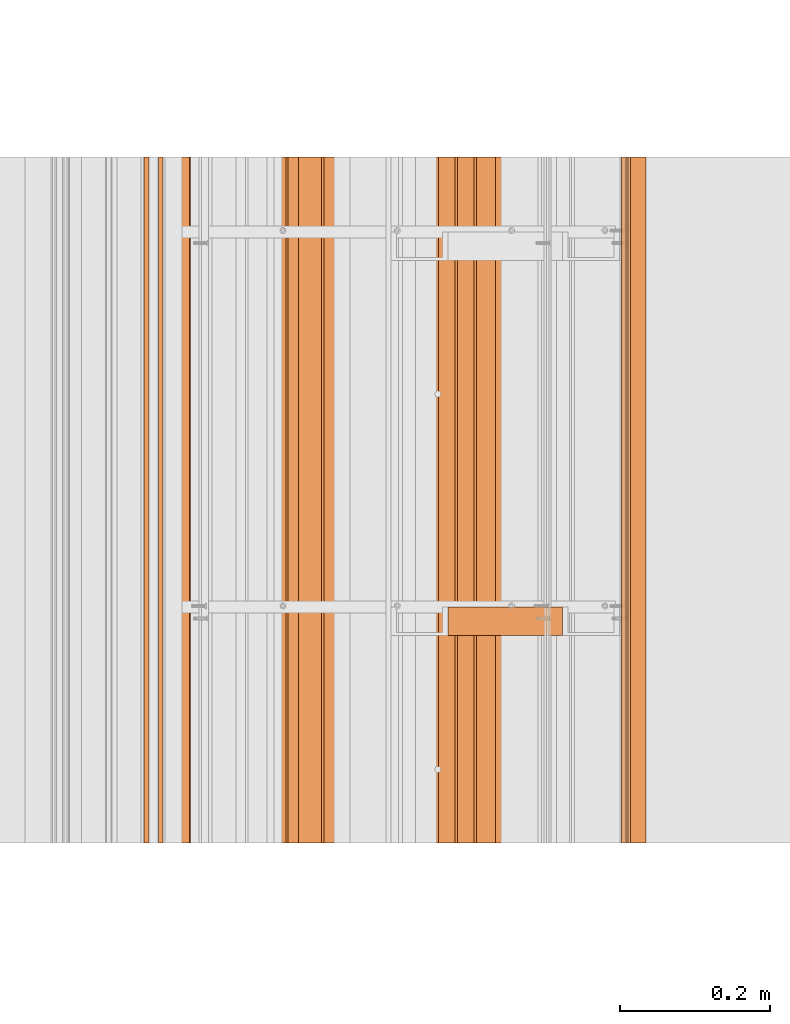
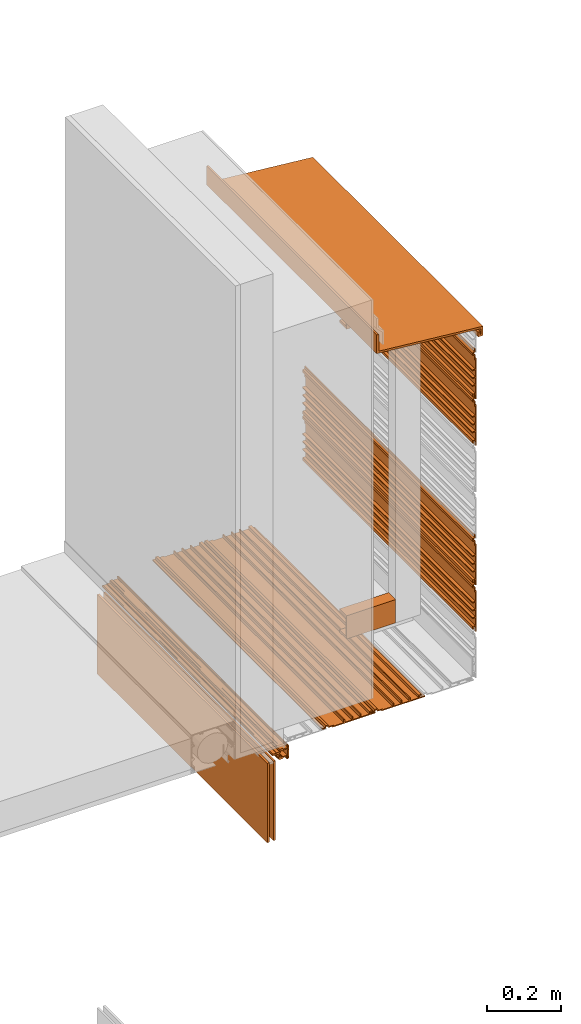
# One storey, part 7 of 36: 12 proxies.
"""IFC2X3 building model written with IfcOpenShell, lengths in feet."""

from ifc_helpers import new_model, entity, si_unit, converted_unit, derived_unit, direction, frame, frame_2d, origin, origin_2d_with_axis, place, context, subcontext, project, spatial, polyline, circle_curve, parameter, trimmed, segment, composite_curve, rectangle, outline, extrude, source, transform, mapped, material, type_object, type_shapes, element, save


model = new_model("IFC2X3")

# Units and contexts
model_context = context("Model", 3, precision=0.0001, world=origin(), true_north=direction((6.12303176911189e-17, 1.0)))
body_context = subcontext(model_context, "Body", "Model", "MODEL_VIEW")
ifc_project = project(units=[converted_unit("LENGTHUNIT", "FOOT", entity("IfcRatioMeasure", 0.3048), si_unit("LENGTHUNIT", "METRE"), dimensions=[1, 0, 0, 0, 0, 0, 0]), converted_unit("AREAUNIT", "SQUARE FOOT", entity("IfcRatioMeasure", 0.09290304), si_unit("AREAUNIT", "SQUARE_METRE"), dimensions=[2, 0, 0, 0, 0, 0, 0]), converted_unit("VOLUMEUNIT", "CUBIC FOOT", entity("IfcRatioMeasure", 0.028316846592), si_unit("VOLUMEUNIT", "CUBIC_METRE"), dimensions=[3, 0, 0, 0, 0, 0, 0]), converted_unit("PLANEANGLEUNIT", "DEGREE", entity("IfcRatioMeasure", 0.0174532925199433), si_unit("PLANEANGLEUNIT", "RADIAN"), dimensions=[0, 0, 0, 0, 0, 0, 0]), si_unit("MASSUNIT", "GRAM", prefix="KILO"), derived_unit("MASSDENSITYUNIT", [(si_unit("MASSUNIT", "GRAM", prefix="KILO"), 1), (si_unit("LENGTHUNIT", "METRE"), -3)]), si_unit("TIMEUNIT", "SECOND"), si_unit("FREQUENCYUNIT", "HERTZ"), si_unit("THERMODYNAMICTEMPERATUREUNIT", "DEGREE_CELSIUS"), derived_unit("THERMALTRANSMITTANCEUNIT", [(si_unit("MASSUNIT", "GRAM", prefix="KILO"), 1), (si_unit("THERMODYNAMICTEMPERATUREUNIT", "KELVIN"), -1), (si_unit("TIMEUNIT", "SECOND"), -3)]), derived_unit("VOLUMETRICFLOWRATEUNIT", [(si_unit("LENGTHUNIT", "METRE"), 3), (si_unit("TIMEUNIT", "SECOND"), -1)]), si_unit("ELECTRICCURRENTUNIT", "AMPERE"), si_unit("ELECTRICVOLTAGEUNIT", "VOLT"), si_unit("POWERUNIT", "WATT"), si_unit("FORCEUNIT", "NEWTON"), si_unit("ILLUMINANCEUNIT", "LUX"), si_unit("LUMINOUSFLUXUNIT", "LUMEN"), si_unit("LUMINOUSINTENSITYUNIT", "CANDELA"), derived_unit("USERDEFINED", [(si_unit("MASSUNIT", "GRAM", prefix="KILO"), -1), (si_unit("LENGTHUNIT", "METRE"), -2), (si_unit("TIMEUNIT", "SECOND"), 3), (si_unit("LUMINOUSFLUXUNIT", "LUMEN"), 1)]), derived_unit("LINEARVELOCITYUNIT", [(si_unit("LENGTHUNIT", "METRE"), 1), (si_unit("TIMEUNIT", "SECOND"), -1)]), si_unit("PRESSUREUNIT", "PASCAL"), derived_unit("USERDEFINED", [(si_unit("LENGTHUNIT", "METRE"), -2), (si_unit("MASSUNIT", "GRAM", prefix="KILO"), 1), (si_unit("TIMEUNIT", "SECOND"), -2)])], contexts=[model_context])

# Site, building, storey
site_placement = place(None, origin())
site = spatial("IfcSite", under=ifc_project, at=site_placement, CompositionType="ELEMENT")
building_placement = place(site_placement, origin())
building = spatial("IfcBuilding", under=site, at=building_placement, CompositionType="ELEMENT")
storey_placement = place(building_placement, origin())
storey = spatial("IfcBuildingStorey", under=building, at=storey_placement, Name="Level 1", CompositionType="ELEMENT", Elevation=0.0)

# Proxies
ifc_material_1 = material(Name="_EXISTING CAST-IN-PLACE CONCRETE")
building_element_proxy_type_1 = type_object("IfcBuildingElementProxyType", Name="panel 062", PredefinedType="NOTDEFINED", material=ifc_material_1)
shared_shape_1 = source(origin(), body_context, "Body", "SweptSolid", [
    extrude(outline(polyline([(-0.145680147068472, -0.0220175316852362), (0.291819852931523, -0.0220175316852362), (0.291819852931523, -0.0116008650185648), (0.237132352931532, -0.0116008650185648), (0.237132352931532, 0.00451787028327999), (0.25796568626486, 0.00451787028327999), (0.25796568626486, 0.0173047730391858), (0.226715686264857, 0.0173047730391858), (0.226715686264857, -0.0116008650185648), (0.143382352931518, -0.0116008650185648), (0.143382352931518, 0.0196491349814352), (0.132965686264866, 0.0196491349814352), (0.132965686264866, -0.0116008650185648), (0.0600490195981784, -0.0116008650185648), (0.0600490195981784, 0.0196491349814352), (0.0496323529315283, 0.0196491349814352), (0.0496323529315283, -0.0116008650185648), (-0.0232843137351342, -0.0116008650185648), (-0.0232843137351342, 0.0196491349814352), (-0.0337009804018109, 0.0196491349814352), (-0.0337009804018109, -0.0116008650185648), (-0.13526348040182, -0.0116008650185648), (-0.13526348040182, -0.00118419835187922), (-0.180710665113102, -0.00118419835187922), (-0.189949600808633, 0.0186287630982349), (-0.215994026661654, 0.0186287630982349), (-0.2252329620291, -0.00118419835187922), (-0.24984681373514, -0.00118419835187922), (-0.24984681373514, -0.0116008650185648), (-0.218596813735134, -0.0116008650185648), (-0.210299318000237, 0.00619317215335968), (-0.195644309470053, 0.00619317215335968), (-0.187346813735154, -0.0116008650185648), (-0.145680147068472, -0.0116008650185648), (-0.145680147068472, -0.0220175316852362)])), frame((125.424633043827, -64.2284331589239, 12.521009163627), z_axis=(0.0, 1.0, 0.0), x_axis=(0.0, 0.0, -1.0)), (0.0, 0.0, 1.0), 3.0),
])
type_shapes(building_element_proxy_type_1, [shared_shape_1])
proxy_1_placement = place(storey_placement, origin())
element("IfcBuildingElementProxy", 1, at=proxy_1_placement, inside=storey, type_object=building_element_proxy_type_1, material=ifc_material_1, Name="panel 062:panel 062", ObjectType="panel 062", context=body_context, shape_type="MappedRepresentation", body=[
    mapped(shared_shape_1, transform((0.0, 0.0, 0.0), scale=1.0)),
])
building_element_proxy_type_2 = type_object("IfcBuildingElementProxyType", Name="panel 063", PredefinedType="NOTDEFINED", material=ifc_material_1)
shared_shape_2 = source(origin(), body_context, "Body", "SweptSolid", [
    extrude(outline(polyline([(-0.145680147068472, -0.0220175316852362), (0.291819852931521, -0.0220175316852362), (0.291819852931521, -0.0116008650185648), (0.237132352931532, -0.0116008650185648), (0.237132352931532, 0.00451787028327999), (0.25796568626486, 0.00451787028327999), (0.25796568626486, 0.0173047730391858), (0.226715686264857, 0.0173047730391858), (0.226715686264857, -0.0116008650185648), (0.143382352931518, -0.0116008650185648), (0.143382352931518, 0.0196491349814352), (0.132965686264866, 0.0196491349814352), (0.132965686264866, -0.0116008650185648), (0.0600490195981784, -0.0116008650185648), (0.0600490195981784, 0.0196491349814352), (0.0496323529315283, 0.0196491349814352), (0.0496323529315283, -0.0116008650185648), (-0.023284313735136, -0.0116008650185648), (-0.023284313735136, 0.0196491349814352), (-0.0337009804018109, 0.0196491349814352), (-0.0337009804018109, -0.0116008650185648), (-0.13526348040182, -0.0116008650185648), (-0.13526348040182, -0.00118419835187922), (-0.1807106651131, -0.00118419835187922), (-0.189949600808632, 0.0186287630982349), (-0.215994026661653, 0.0186287630982349), (-0.2252329620291, -0.00118419835187922), (-0.24984681373514, -0.00118419835187922), (-0.24984681373514, -0.0116008650185648), (-0.218596813735134, -0.0116008650185648), (-0.210299318000237, 0.00619317215335968), (-0.195644309470051, 0.00619317215335968), (-0.187346813735154, -0.0116008650185648), (-0.145680147068472, -0.0116008650185648), (-0.145680147068472, -0.0220175316852362)])), frame((125.424633043827, -64.2284331589239, 13.021009163627), z_axis=(0.0, 1.0, 0.0), x_axis=(0.0, 0.0, -1.0)), (0.0, 0.0, 1.0), 3.0),
])
type_shapes(building_element_proxy_type_2, [shared_shape_2])
proxy_2_placement = place(storey_placement, origin())
element("IfcBuildingElementProxy", 2, at=proxy_2_placement, inside=storey, type_object=building_element_proxy_type_2, material=ifc_material_1, Name="panel 063:panel 063", ObjectType="panel 063", context=body_context, shape_type="MappedRepresentation", body=[
    mapped(shared_shape_2, transform((0.0, 0.0, 0.0), scale=1.0)),
])
building_element_proxy_type_3 = type_object("IfcBuildingElementProxyType", Name="panel 064", PredefinedType="NOTDEFINED", material=ifc_material_1)
shared_shape_3 = source(origin(), body_context, "Body", "SweptSolid", [
    extrude(outline(polyline([(0.0116008650030874, -0.29181985294116), (0.0220175316697411, -0.29181985294116), (0.0220175316697411, 0.145680147058869), (0.0116008650030874, 0.145680147058869), (0.0116008650030874, 0.187346813725526), (-0.00619317207042336, 0.195644309526045), (-0.00619317207042336, 0.210299317925006), (0.0116008650030874, 0.218596813725526), (0.0116008650030874, 0.24984681372554), (0.0011841983364107, 0.24984681372554), (0.0011841983364107, 0.22523296228195), (-0.0186287629496711, 0.215994026619228), (-0.0186287629496711, 0.189949600831824), (0.0011841983364107, 0.180710665169102), (0.0011841983364107, 0.135263480392183), (0.0116008650030874, 0.135263480392183), (0.0116008650030874, 0.0337009803921688), (-0.0196491349969179, 0.0337009803921688), (-0.0196491349969179, 0.0232843137255401), (0.0116008650030874, 0.0232843137255401), (0.0116008650030874, -0.0496323529411313), (-0.0196491349969179, -0.0496323529411313), (-0.0196491349969179, -0.0600490196078169), (0.0116008650030874, -0.0600490196078169), (0.0116008650030874, -0.132965686274474), (-0.0196491349969179, -0.132965686274474), (-0.0196491349969179, -0.143382352941146), (0.0116008650030874, -0.143382352941146), (0.0116008650030874, -0.226715686274488), (-0.0173047731202853, -0.226715686274488), (-0.0173047731202853, -0.257965686274474), (-0.00451787023313521, -0.257965686274474), (-0.00451787023313521, -0.237132352941131), (0.0116008650030874, -0.237132352941131), (0.0116008650030874, -0.29181985294116)])), frame((124.628789055904, -64.2284331589239, 9.73037350903193), z_axis=(0.0, 1.0, 0.0), x_axis=(0.0, 0.0, -1.0)), (0.0, 0.0, 1.0), 3.0),
])
type_shapes(building_element_proxy_type_3, [shared_shape_3])
proxy_3_placement = place(storey_placement, origin())
element("IfcBuildingElementProxy", 3, at=proxy_3_placement, inside=storey, type_object=building_element_proxy_type_3, material=ifc_material_1, Name="panel 064:panel 064", ObjectType="panel 064", context=body_context, shape_type="MappedRepresentation", body=[
    mapped(shared_shape_3, transform((0.0, 0.0, 0.0), scale=1.0)),
])
building_element_proxy_type_4 = type_object("IfcBuildingElementProxyType", Name="panel 065", PredefinedType="NOTDEFINED", material=ifc_material_1)
shared_shape_4 = source(origin(), body_context, "Body", "SweptSolid", [
    extrude(outline(polyline([(0.0116008650030874, -0.29181985294116), (0.0220175316697411, -0.29181985294116), (0.0220175316697411, 0.145680147058869), (0.0116008650030874, 0.145680147058869), (0.0116008650030874, 0.187346813725526), (-0.00619317207042336, 0.195644309526045), (-0.00619317207042336, 0.210299317925006), (0.0116008650030874, 0.218596813725526), (0.0116008650030874, 0.24984681372554), (0.0011841983364107, 0.24984681372554), (0.0011841983364107, 0.22523296228195), (-0.0186287629496711, 0.215994026619228), (-0.0186287629496711, 0.189949600831824), (0.0011841983364107, 0.180710665169102), (0.0011841983364107, 0.135263480392183), (0.0116008650030874, 0.135263480392183), (0.0116008650030874, 0.0337009803921688), (-0.0196491349969179, 0.0337009803921688), (-0.0196491349969179, 0.0232843137255401), (0.0116008650030874, 0.0232843137255401), (0.0116008650030874, -0.0496323529411313), (-0.0196491349969179, -0.0496323529411313), (-0.0196491349969179, -0.0600490196078169), (0.0116008650030874, -0.0600490196078169), (0.0116008650030874, -0.132965686274474), (-0.0196491349969179, -0.132965686274474), (-0.0196491349969179, -0.143382352941146), (0.0116008650030874, -0.143382352941146), (0.0116008650030874, -0.226715686274488), (-0.0173047731202853, -0.226715686274488), (-0.0173047731202853, -0.257965686274474), (-0.00451787023313521, -0.257965686274474), (-0.00451787023313521, -0.237132352941131), (0.0116008650030874, -0.237132352941131), (0.0116008650030874, -0.29181985294116)])), frame((124.128789055904, -64.2284331589239, 9.73037350903193), z_axis=(0.0, 1.0, 0.0), x_axis=(0.0, 0.0, -1.0)), (0.0, 0.0, 1.0), 3.0),
])
type_shapes(building_element_proxy_type_4, [shared_shape_4])
proxy_4_placement = place(storey_placement, origin())
element("IfcBuildingElementProxy", 4, at=proxy_4_placement, inside=storey, type_object=building_element_proxy_type_4, material=ifc_material_1, Name="panel 065:panel 065", ObjectType="panel 065", context=body_context, shape_type="MappedRepresentation", body=[
    mapped(shared_shape_4, transform((0.0, 0.0, 0.0), scale=1.0)),
])
building_element_proxy_type_5 = type_object("IfcBuildingElementProxyType", Name="panel 066", PredefinedType="NOTDEFINED", material=ifc_material_1)
shared_shape_5 = source(origin(), body_context, "Body", "SweptSolid", [
    extrude(outline(polyline([(-0.145680147068472, -0.0220175316852362), (0.291819852931523, -0.0220175316852362), (0.291819852931523, -0.0116008650185648), (0.237132352931534, -0.0116008650185648), (0.237132352931534, 0.00451787028327999), (0.257965686264862, 0.00451787028327999), (0.257965686264862, 0.0173047730391858), (0.226715686264857, 0.0173047730391858), (0.226715686264857, -0.0116008650185648), (0.143382352931519, -0.0116008650185648), (0.143382352931519, 0.0196491349814352), (0.132965686264866, 0.0196491349814352), (0.132965686264866, -0.0116008650185648), (0.0600490195981802, -0.0116008650185648), (0.0600490195981802, 0.0196491349814352), (0.0496323529315283, 0.0196491349814352), (0.0496323529315283, -0.0116008650185648), (-0.0232843137351342, -0.0116008650185648), (-0.0232843137351342, 0.0196491349814352), (-0.0337009804018091, 0.0196491349814352), (-0.0337009804018091, -0.0116008650185648), (-0.135263480401818, -0.0116008650185648), (-0.135263480401818, -0.00118419835187922), (-0.1807106651131, -0.00118419835187922), (-0.189949600808632, 0.0186287630982349), (-0.215994026661653, 0.0186287630982349), (-0.2252329620291, -0.00118419835187922), (-0.249846813735138, -0.00118419835187922), (-0.249846813735138, -0.0116008650185648), (-0.218596813735134, -0.0116008650185648), (-0.210299318000235, 0.00619317215335968), (-0.195644309470051, 0.00619317215335968), (-0.187346813735154, -0.0116008650185648), (-0.145680147068472, -0.0116008650185648), (-0.145680147068472, -0.0220175316852362)])), frame((125.424633043827, -64.2284331589239, 11.021009163627), z_axis=(0.0, 1.0, 0.0), x_axis=(0.0, 0.0, -1.0)), (0.0, 0.0, 1.0), 3.0),
])
type_shapes(building_element_proxy_type_5, [shared_shape_5])
proxy_5_placement = place(storey_placement, origin())
element("IfcBuildingElementProxy", 5, at=proxy_5_placement, inside=storey, type_object=building_element_proxy_type_5, material=ifc_material_1, Name="panel 066:panel 066", ObjectType="panel 066", context=body_context, shape_type="MappedRepresentation", body=[
    mapped(shared_shape_5, transform((0.0, 0.0, 0.0), scale=1.0)),
])
building_element_proxy_type_6 = type_object("IfcBuildingElementProxyType", Name="panel 067", PredefinedType="NOTDEFINED", material=ifc_material_1)
shared_shape_6 = source(origin(), body_context, "Body", "SweptSolid", [
    extrude(outline(polyline([(-0.14568014706847, -0.0220175316852362), (0.291819852931525, -0.0220175316852362), (0.291819852931525, -0.0116008650185648), (0.237132352931535, -0.0116008650185648), (0.237132352931535, 0.00451787028327999), (0.257965686264864, 0.00451787028327999), (0.257965686264864, 0.0173047730391858), (0.226715686264859, 0.0173047730391858), (0.226715686264859, -0.0116008650185648), (0.143382352931521, -0.0116008650185648), (0.143382352931521, 0.0196491349814352), (0.132965686264868, 0.0196491349814352), (0.132965686264868, -0.0116008650185648), (0.060049019598182, -0.0116008650185648), (0.060049019598182, 0.0196491349814352), (0.0496323529315301, 0.0196491349814352), (0.0496323529315301, -0.0116008650185648), (-0.0232843137351324, -0.0116008650185648), (-0.0232843137351324, 0.0196491349814352), (-0.0337009804018074, 0.0196491349814352), (-0.0337009804018074, -0.0116008650185648), (-0.135263480401816, -0.0116008650185648), (-0.135263480401816, -0.00118419835187922), (-0.180710665113098, -0.00118419835187922), (-0.18994960080863, 0.0186287630982349), (-0.215994026661651, 0.0186287630982349), (-0.225232962029096, -0.00118419835187922), (-0.249846813735136, -0.00118419835187922), (-0.249846813735136, -0.0116008650185648), (-0.218596813735132, -0.0116008650185648), (-0.210299318000233, 0.00619317215335968), (-0.195644309470049, 0.00619317215335968), (-0.18734681373515, -0.0116008650185648), (-0.14568014706847, -0.0116008650185648), (-0.14568014706847, -0.0220175316852362)])), frame((125.424633043827, -64.2284331589239, 10.521009163627), z_axis=(0.0, 1.0, 0.0), x_axis=(0.0, 0.0, -1.0)), (0.0, 0.0, 1.0), 3.0),
])
type_shapes(building_element_proxy_type_6, [shared_shape_6])
proxy_6_placement = place(storey_placement, origin())
element("IfcBuildingElementProxy", 6, at=proxy_6_placement, inside=storey, type_object=building_element_proxy_type_6, material=ifc_material_1, Name="panel 067:panel 067", ObjectType="panel 067", context=body_context, shape_type="MappedRepresentation", body=[
    mapped(shared_shape_6, transform((0.0, 0.0, 0.0), scale=1.0)),
])
building_element_proxy_type_7 = type_object("IfcBuildingElementProxyType", Name="Metal stud 028", PredefinedType="NOTDEFINED", material=ifc_material_1)
shared_shape_7 = source(origin(), body_context, "Body", "SweptSolid", [
    extrude(outline(polyline([(-0.066190944881896, -0.125), (0.058809055118104, -0.125), (0.058809055118104, -0.100393700787402), (-0.0514271653543332, -0.100393700787402), (-0.0514271653543332, 0.100393700787404), (0.058809055118104, 0.100393700787404), (0.058809055118104, 0.125000000000002), (-0.066190944881896, 0.125000000000002), (-0.066190944881896, -0.125)])), frame((124.647701703619, -63.2557461510499, 10.0), z_axis=(1.0, 0.0, 0.0), x_axis=(0.0, 1.0, 0.0)), (0.0, 0.0, 1.0), 0.5),
])
type_shapes(building_element_proxy_type_7, [shared_shape_7])
proxy_7_placement = place(storey_placement, origin())
element("IfcBuildingElementProxy", 7, at=proxy_7_placement, inside=storey, type_object=building_element_proxy_type_7, material=ifc_material_1, Name="Metal stud 028:Metal stud 028", ObjectType="Metal stud 028", context=body_context, shape_type="MappedRepresentation", body=[
    mapped(shared_shape_7, transform((0.0, 0.0, 0.0), scale=1.0)),
])
building_element_proxy_type_8 = type_object("IfcBuildingElementProxyType", Name="Counter-flashing 005", PredefinedType="NOTDEFINED", material=ifc_material_1)
shared_shape_8 = source(origin(), body_context, "Body", "SweptSolid", [
    extrude(outline(polyline([(-0.374644447526265, -0.122649832506564), (-0.32335569260502, -0.122649832506564), (-0.32335569260502, -0.0712265118864863), (-0.344552994114181, -0.0712265118864863), (-0.344552994114181, -0.101456535928891), (-0.353447146017089, -0.101456535928891), (-0.353447146017089, -0.0436645732176864), (0.70859661243108, 0.0592285252280149), (0.70859661243108, 0.260425070602032), (0.687403667831262, 0.260425070602032), (0.687403667831262, 0.0785724214419616), (-0.374644447526265, -0.0243207540124679), (-0.374644447526265, -0.122649832506564)])), frame((125.1389707854, -64.2284331589238, 13.5125295948507), z_axis=(0.0, 1.0, 0.0), x_axis=(-1.0, 0.0, 0.0)), (0.0, 0.0, 1.0), 3.0),
])
type_shapes(building_element_proxy_type_8, [shared_shape_8])
proxy_8_placement = place(storey_placement, origin())
element("IfcBuildingElementProxy", 8, at=proxy_8_placement, inside=storey, type_object=building_element_proxy_type_8, material=ifc_material_1, Name="Counter-flashing 005:Counter-flashing 005", ObjectType="Counter-flashing 005", context=body_context, shape_type="MappedRepresentation", body=[
    mapped(shared_shape_8, transform((0.0, 0.0, 0.0), scale=1.0)),
])
ifc_material_2 = material(Name="Clear glass")
building_element_proxy_type_9 = type_object("IfcBuildingElementProxyType", Name="Glass panel 025", PredefinedType="NOTDEFINED", material=ifc_material_2)
shared_shape_9 = source(origin(), body_context, "Body", "SweptSolid", [
    extrude(rectangle(XDim=3.0, YDim=0.020833333333357, at=frame_2d((0.0, 7.105427357601e-15), x_axis=(1.0, 0.0))), frame((123.328165433694, -62.7284331589239, 8.69746645084646), z_axis=(0.0, 0.0, 1.0), x_axis=(0.0, 1.0, 0.0)), (0.0, 0.0, 1.0), 0.8546168825),
])
type_shapes(building_element_proxy_type_9, [shared_shape_9])
proxy_9_placement = place(storey_placement, origin())
element("IfcBuildingElementProxy", 9, at=proxy_9_placement, inside=storey, type_object=building_element_proxy_type_9, material=ifc_material_2, Name="Glass panel 025:Glass panel 025", ObjectType="Glass panel 025", context=body_context, shape_type="MappedRepresentation", body=[
    mapped(shared_shape_9, transform((0.0, 0.0, 0.0), scale=1.0)),
])
building_element_proxy_type_10 = type_object("IfcBuildingElementProxyType", Name="Glass panel 026", PredefinedType="NOTDEFINED", material=ifc_material_2)
shared_shape_10 = source(origin(), body_context, "Body", "SweptSolid", [
    extrude(rectangle(XDim=3.0, YDim=0.0208333333333428, at=origin_2d_with_axis()), frame((123.390665433694, -62.7284331589239, 8.69746645084646), z_axis=(0.0, 0.0, 1.0), x_axis=(0.0, 1.0, 0.0)), (0.0, 0.0, 1.0), 0.8546168825),
])
type_shapes(building_element_proxy_type_10, [shared_shape_10])
proxy_10_placement = place(storey_placement, origin())
element("IfcBuildingElementProxy", 10, at=proxy_10_placement, inside=storey, type_object=building_element_proxy_type_10, material=ifc_material_2, Name="Glass panel 026:Glass panel 026", ObjectType="Glass panel 026", context=body_context, shape_type="MappedRepresentation", body=[
    mapped(shared_shape_10, transform((0.0, 0.0, 0.0), scale=1.0)),
])
ifc_material_3 = material(Name="Window frame")
building_element_proxy_type_11 = type_object("IfcBuildingElementProxyType", Name="Window frame part 100", PredefinedType="NOTDEFINED", material=ifc_material_3)
shared_shape_11 = source(origin(), body_context, "Body", "SweptSolid", [
    extrude(outline(composite_curve([segment(polyline([(-0.00438075835132877, 0.0375981568845754), (-0.00954742501801861, 0.0325714293846029)]), True, "CONTINUOUS"), segment(polyline([(-0.00954742501801861, 0.0325714293846029), (-0.039354030018016, 0.0325714293847345)]), True, "CONTINUOUS"), segment(polyline([(-0.039354030018016, 0.0325714293847345), (-0.0443807583513297, 0.037598156884752)]), True, "CONTINUOUS"), segment(polyline([(-0.0443807583513297, 0.037598156884752), (-0.0493390916846784, 0.0375981568847739)]), True, "CONTINUOUS"), segment(trimmed(circle_curve(frame_2d((-0.0493390916847244, 0.0271814902182446), x_axis=(0.0, -1.0)), 0.0104166666666664), [parameter(180.0)], [parameter(270.0)], True, "PARAMETER"), True, "CONTINUOUS"), segment(polyline([(-0.0597557583513905, 0.0271814902182906), (-0.0597557583515066, -0.00274216978183169)]), True, "CONTINUOUS"), segment(polyline([(-0.0597557583515066, -0.00274216978183169), (-0.0495057583515557, -0.0136825264485569)]), True, "CONTINUOUS"), segment(polyline([(-0.0495057583515557, -0.0136825264485569), (-0.0495057583517403, -0.0554851764484371)]), True, "CONTINUOUS"), segment(trimmed(circle_curve(frame_2d((-0.0511724250181212, -0.0554851764484298), x_axis=(0.0, -1.0)), 0.00166666666666629), [parameter(0.0)], [parameter(90.0000000000001)], True, "PARAMETER"), False, "CONTINUOUS"), segment(polyline([(-0.0511724250181285, -0.0571518431150949), (-0.0666724250180835, -0.057151843115126)]), True, "CONTINUOUS"), segment(trimmed(circle_curve(frame_2d((-0.0666724250180762, -0.0554851764483613), x_axis=(0.0, -1.0)), 0.00166666666666634), [parameter(270.0)], [parameter(0.0)], True, "PARAMETER"), False, "CONTINUOUS"), segment(polyline([(-0.0683390916847431, -0.055485176448354), (-0.0683390916850497, -0.0504851764484722)]), True, "CONTINUOUS"), segment(trimmed(circle_curve(frame_2d((-0.0700057583519244, -0.0504851764484648), x_axis=(0.0, -1.0)), 0.00166666666666678), [parameter(90.0000000000001)], [parameter(180.0)], True, "PARAMETER"), True, "CONTINUOUS"), segment(polyline([(-0.0700057583519171, -0.0488185097817997), (-0.0770890916848958, -0.0488185097817826)]), True, "CONTINUOUS"), segment(trimmed(circle_curve(frame_2d((-0.0770890916849031, -0.0504851764484336), x_axis=(0.0, -1.0)), 0.00166666666666672), [parameter(180.0)], [parameter(270.0)], True, "PARAMETER"), True, "CONTINUOUS"), segment(polyline([(-0.0787557583515701, -0.0504851764484262), (-0.0787557583517469, -0.0571518431150442)]), True, "CONTINUOUS"), segment(trimmed(circle_curve(frame_2d((-0.0683390916850187, -0.0571518431150902), x_axis=(0.0, -1.0)), 0.0104166666666664), [parameter(270.0)], [parameter(0.0)], True, "PARAMETER"), True, "CONTINUOUS"), segment(polyline([(-0.0683390916850647, -0.0675685097817616), (0.0608275749814792, -0.0675685097823745)]), True, "CONTINUOUS"), segment(trimmed(circle_curve(frame_2d((0.0608275749815252, -0.0571518431156605), x_axis=(0.0, -1.0)), 0.010416666666665), [parameter(0.0)], [parameter(90.0000000000001)], True, "PARAMETER"), True, "CONTINUOUS"), segment(polyline([(0.0712442416481895, -0.0571518431157064), (0.0712442416482828, -0.0504851764490885)]), True, "CONTINUOUS"), segment(trimmed(circle_curve(frame_2d((0.0695775749814703, -0.0504851764490811), x_axis=(0.0, -1.0)), 0.0016666666666669), [parameter(90.0000000000001)], [parameter(180.0)], True, "PARAMETER"), True, "CONTINUOUS"), segment(polyline([(0.0695775749814776, -0.048818509782416), (0.0624942416484971, -0.0488185097823989)]), True, "CONTINUOUS"), segment(trimmed(circle_curve(frame_2d((0.0624942416484898, -0.0504851764490498), x_axis=(0.0, -1.0)), 0.00166666666666623), [parameter(180.0)], [parameter(270.0)], True, "PARAMETER"), True, "CONTINUOUS"), segment(polyline([(0.0608275749818228, -0.0504851764490425), (0.0608275749815947, -0.0554851764489243)]), True, "CONTINUOUS"), segment(trimmed(circle_curve(frame_2d((0.0591609083153434, -0.0554851764489169), x_axis=(0.0, -1.0)), 0.00166666666666606), [parameter(0.0)], [parameter(90.0000000000001)], True, "PARAMETER"), False, "CONTINUOUS"), segment(polyline([(0.0591609083153361, -0.057151843115582), (0.043660908314635, -0.0571518431156131)]), True, "CONTINUOUS"), segment(trimmed(circle_curve(frame_2d((0.0436609083146424, -0.0554851764488485), x_axis=(0.0, -1.0)), 0.00166666666666655), [parameter(270.0000008691)], [parameter(0.0)], True, "PARAMETER"), False, "CONTINUOUS"), segment(polyline([(0.0419942416479754, -0.0554851764741222), (0.0424823974817821, -0.0125040147822972)]), True, "CONTINUOUS"), segment(polyline([(0.0424823974817821, -0.0125040147822972), (0.0522442416484935, -0.00274216978232618)]), True, "CONTINUOUS"), segment(polyline([(0.0522442416484935, -0.00274216978232618), (0.0522442416485671, 0.0139314902177968)]), True, "CONTINUOUS"), segment(trimmed(circle_curve(frame_2d((0.0418275749819188, 0.0139314902178427), x_axis=(0.0, -1.0)), 0.0104166666666674), [parameter(90.0000000000001)], [parameter(180.0)], True, "PARAMETER"), True, "CONTINUOUS"), segment(polyline([(0.0418275749819648, 0.0243481568845142), (0.0268484083156127, 0.024348156884424)]), True, "CONTINUOUS"), segment(trimmed(circle_curve(frame_2d((0.02684840831562, 0.0260148235511318), x_axis=(0.0, -1.0)), 0.00166666666666634), [parameter(270.0)], [parameter(0.0)], True, "PARAMETER"), False, "CONTINUOUS"), segment(polyline([(0.0251817416489531, 0.0260148235511391), (0.0251817416487481, 0.0548241702178015)]), True, "CONTINUOUS"), segment(polyline([(0.0251817416487481, 0.0548241702178015), (0.0220567416487612, 0.0579491702177982)]), True, "CONTINUOUS"), segment(polyline([(0.0220567416487612, 0.0579491702177982), (0.0220567416488808, 0.0850325035511211)]), True, "CONTINUOUS"), segment(polyline([(0.0220567416488808, 0.0850325035511211), (0.0251817416488953, 0.0881575035511045)]), True, "CONTINUOUS"), segment(polyline([(0.0251817416488953, 0.0881575035511045), (0.0251817416489174, 0.0931575035511426)]), True, "CONTINUOUS"), segment(trimmed(circle_curve(frame_2d((0.0144525749822676, 0.0931575035511899), x_axis=(0.0, -1.0)), 0.0107291666666668), [parameter(90.0000000000001)], [parameter(270.0)], True, "PARAMETER"), True, "CONTINUOUS"), segment(polyline([(0.00372340831559998, 0.0931575035512373), (0.00372340831556016, 0.0881616435512007)]), True, "CONTINUOUS"), segment(polyline([(0.00372340831556016, 0.0881616435512007), (0.00684840831554885, 0.085036643551204)]), True, "CONTINUOUS"), segment(polyline([(0.00684840831554885, 0.085036643551204), (0.00684840831542926, 0.0579491702178653)]), True, "CONTINUOUS"), segment(polyline([(0.00684840831542926, 0.0579491702178653), (0.00372340831541298, 0.0548241702178962)]), True, "CONTINUOUS"), segment(polyline([(0.00372340831541298, 0.0548241702178962), (0.00372340831534428, 0.0392648235512332)]), True, "CONTINUOUS"), segment(trimmed(circle_curve(frame_2d((0.00205674164912855, 0.0392648235512405), x_axis=(0.0, -1.0)), 0.00166666666666623), [parameter(0.0)], [parameter(90.0000000000001)], True, "PARAMETER"), False, "CONTINUOUS"), segment(polyline([(0.00205674164912119, 0.0375981568845754), (-0.00438075835132877, 0.0375981568845754)]), True, "CONTINUOUS")], self_intersect=False), holes=[polyline([(-0.0299691200180624, 0.0221547627180074), (-0.00531622835139511, 0.0221547627178986), (-0.000149561684707042, 0.0271814902179137), (0.0147650749819582, 0.0271814902178479), (0.0147650749819376, 0.0225148235511684), (0.0264832424818914, 0.0120981568844452), (0.0294313533152304, 0.0133203793844225), (0.0294313533151784, 0.00154260105108301), (0.0235387983151675, -0.00434995394887939), (0.0315775749817887, -0.0100833839488787), (0.0299109083149211, -0.0571518431155666), (-0.0390890916850724, -0.055485176448611), (-0.0379148491848655, -0.00849112311529468), (-0.0310484808515309, -0.00434812061529547), (-0.0369392025181557, 0.00154260105137605), (-0.0369392025181037, 0.0133167127180439), (-0.0311391175180767, 0.0193011318846981), (-0.0299691200180624, 0.0221547627180074)])]), frame((123.468452027246, -64.2284331589239, 9.60792242503128), z_axis=(0.0, -1.0, 0.0), x_axis=(0.0, 0.0, 1.0)), (0.0, 0.0, -1.0), 3.0),
])
type_shapes(building_element_proxy_type_11, [shared_shape_11])
proxy_11_placement = place(storey_placement, origin())
element("IfcBuildingElementProxy", 11, at=proxy_11_placement, inside=storey, type_object=building_element_proxy_type_11, material=ifc_material_3, Name="Window frame part 100:Window frame part 100", ObjectType="Window frame part 100", context=body_context, shape_type="MappedRepresentation", body=[
    mapped(shared_shape_11, transform((0.0, 0.0, 0.0), scale=1.0)),
])
building_element_proxy_type_12 = type_object("IfcBuildingElementProxyType", Name="Metal stud 032", PredefinedType="NOTDEFINED", material=ifc_material_1)
shared_shape_12 = source(origin(), body_context, "Body", "SweptSolid", [
    extrude(outline(polyline([(-0.066190944881896, -0.125), (0.058809055118104, -0.125), (0.058809055118104, -0.1003937007874), (-0.0514271653543332, -0.1003937007874), (-0.0514271653543332, 0.1003937007874), (0.058809055118104, 0.1003937007874), (0.058809055118104, 0.125), (-0.066190944881896, 0.125), (-0.066190944881896, -0.125)])), frame((124.647701703619, -63.2557461510499, 13.3333333333333), z_axis=(1.0, 0.0, 0.0), x_axis=(0.0, 1.0, 0.0)), (0.0, 0.0, 1.0), 0.5),
])
type_shapes(building_element_proxy_type_12, [shared_shape_12])
proxy_12_placement = place(storey_placement, origin())
element("IfcBuildingElementProxy", 12, at=proxy_12_placement, inside=storey, type_object=building_element_proxy_type_12, material=ifc_material_1, Name="Metal stud 032:Metal stud 032", ObjectType="Metal stud 032", context=body_context, shape_type="MappedRepresentation", body=[
    mapped(shared_shape_12, transform((0.0, 0.0, 0.0), scale=1.0)),
])

save(model, "model.ifc")
